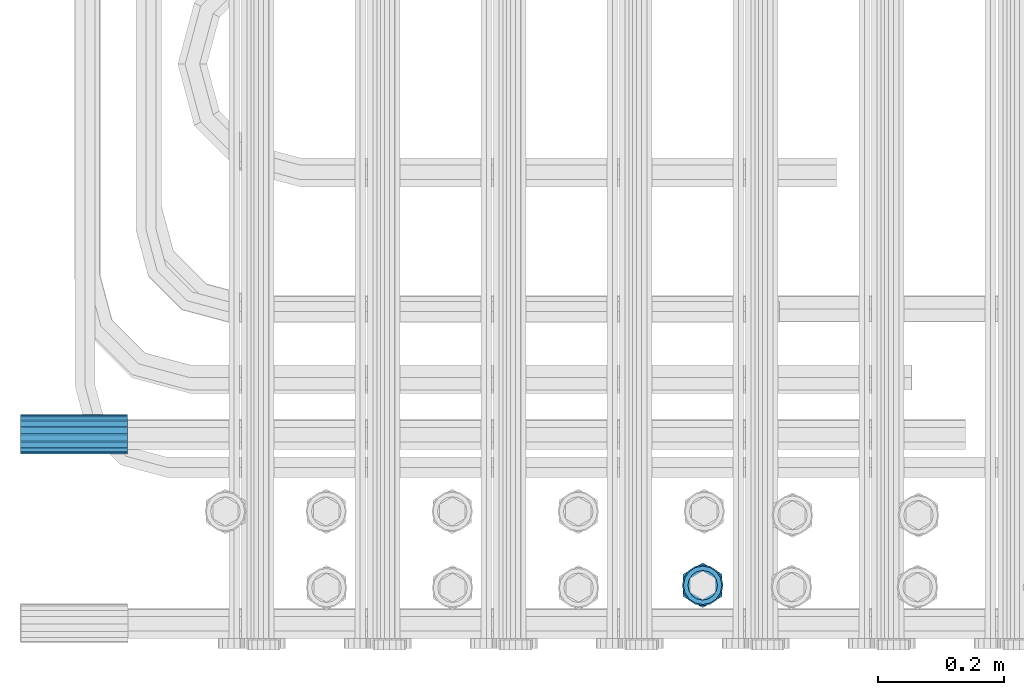
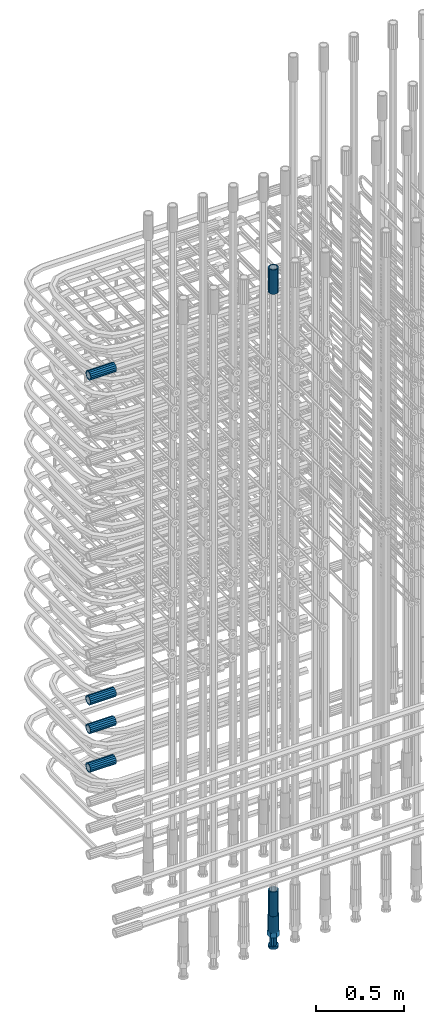
# One storey, part 31 of 177: 7 beams.
"""IFC2X3 building model written with IfcOpenShell, lengths in millimetres."""

from ifc_helpers import new_model, si_unit, frame, origin_with_axes, place, context, subcontext, project, spatial, faceted_brep, material, type_object, element, save


model = new_model("IFC2X3")

# Units and contexts
model_context_1 = context("Model", 3, precision=1e-05, world=origin_with_axes())
model_context_2 = context("Model", 3, precision=1e-05, world=origin_with_axes())
body_context = subcontext(model_context_2, "Body", "Model", "MODEL_VIEW")
ifc_project = project(units=[si_unit("LENGTHUNIT", "METRE", prefix="MILLI"), si_unit("AREAUNIT", "SQUARE_METRE"), si_unit("VOLUMEUNIT", "CUBIC_METRE"), si_unit("MASSUNIT", "GRAM", prefix="KILO"), si_unit("TIMEUNIT", "SECOND"), si_unit("PLANEANGLEUNIT", "RADIAN"), si_unit("SOLIDANGLEUNIT", "STERADIAN"), si_unit("THERMODYNAMICTEMPERATUREUNIT", "DEGREE_CELSIUS"), si_unit("LUMINOUSINTENSITYUNIT", "LUMEN")], contexts=[model_context_1])

# Site, building, storey
site_placement = place(None, origin_with_axes())
site = spatial("IfcSite", under=ifc_project, at=site_placement, CompositionType="ELEMENT")
building_placement = place(site_placement, origin_with_axes())
building = spatial("IfcBuilding", under=site, at=building_placement, Name="Undefined", CompositionType="ELEMENT")
storey_placement = place(building_placement, origin_with_axes())
storey = spatial("IfcBuildingStorey", under=building, at=storey_placement, Name="Undefined", CompositionType="ELEMENT", Elevation=0.0)

# Beams
ifc_material = material(Name="STEEL/S275")
beam_type_1 = type_object("IfcBeamType", PredefinedType="NOTDEFINED")
beam_1_placement = place(storey_placement, frame((2029920.00847313, 6205398.93588033, 22308.9883264263), z_axis=(0.0, 0.0, 1.0), x_axis=(-1.0, 0.0, 0.0)))
element("IfcBeam", 1, at=beam_1_placement, inside=storey, type_object=beam_type_1, material=ifc_material, Name="AG40N", context=body_context, shape_type="Brep", body=[
    faceted_brep([(0.0, -23.5000000001164, -9.31322574615479e-10), (0.0, -21.7111690140155, 8.99306066054851), (170.0, -21.7111690140155, 8.99306066054851), (170.0, -23.5, 0.0), (0.0, -16.6170093578839, 16.6170093575493), (170.0, -16.6170093578839, 16.6170093575493), (0.0, -8.99306066057943, 21.7111690137535), (170.0, -8.99306066057943, 21.7111690137535), (0.0, 1.16415321826935e-10, 23.5), (170.0, 0.0, 23.5), (0.0, 8.99306066057943, 21.7111690137535), (170.0, 8.99306066057943, 21.7111690137535), (0.0, 16.6170093578839, 16.6170093575493), (170.0, 16.6170093578839, 16.6170093575493), (0.0, 21.7111690140155, 8.99306066054851), (170.0, 21.7111690140155, 8.99306066054851), (0.0, 23.5000000001164, -9.31322574615479e-10), (170.0, 23.5, 0.0), (0.0, 21.7111690140155, -8.99306066054851), (170.0, 21.7111690140155, -8.99306066054851), (0.0, 16.6170093578839, -16.6170093575493), (170.0, 16.6170093578839, -16.6170093575493), (0.0, 8.99306066057943, -21.7111690137535), (170.0, 8.99306066057943, -21.7111690137535), (0.0, 1.16415321826935e-10, -23.5000000009313), (170.0, 0.0, -23.5), (0.0, -8.99306066057943, -21.7111690137535), (170.0, -8.99306066057943, -21.7111690137535), (0.0, -16.6170093578839, -16.6170093575493), (170.0, -16.6170093578839, -16.6170093575493), (0.0, -21.7111690140155, -8.99306066054851), (170.0, -21.7111690140155, -8.99306066054851), (0.0, -30.5, 0.0), (0.0, -28.1783257415937, -11.6718446873128), (170.0, -28.1783257415937, -11.6718446873128), (170.0, -30.5, 0.0), (0.0, -21.5667568261888, -21.5667568258941), (170.0, -21.5667568261888, -21.5667568258941), (0.0, -11.6718446871346, -28.1783257415518), (170.0, -11.6718446871346, -28.1783257415518), (0.0, 0.0, -30.5), (170.0, 0.0, -30.5), (0.0, 11.6718446871346, -28.1783257415518), (170.0, 11.6718446871346, -28.1783257415518), (0.0, 21.5667568261888, -21.5667568258941), (170.0, 21.5667568261888, -21.5667568258941), (0.0, 28.1783257415937, -11.6718446873128), (170.0, 28.1783257415937, -11.6718446873128), (0.0, 30.5, 0.0), (170.0, 30.5, 0.0), (0.0, 28.1783257415937, 11.6718446873128), (170.0, 28.1783257415937, 11.6718446873128), (0.0, 21.5667568261888, 21.5667568258941), (170.0, 21.5667568261888, 21.5667568258941), (0.0, 11.6718446871346, 28.1783257415518), (170.0, 11.6718446871346, 28.1783257415518), (0.0, 0.0, 30.5), (170.0, 0.0, 30.5), (0.0, -11.6718446871346, 28.1783257415518), (170.0, -11.6718446871346, 28.1783257415518), (0.0, -21.5667568261888, 21.5667568258941), (170.0, -21.5667568261888, 21.5667568258941), (0.0, -28.1783257415937, 11.6718446873128), (170.0, -28.1783257415937, 11.6718446873128)], [[[0, 1, 2, 3]], [[1, 4, 5, 2]], [[4, 6, 7, 5]], [[6, 8, 9, 7]], [[8, 10, 11, 9]], [[10, 12, 13, 11]], [[12, 14, 15, 13]], [[14, 16, 17, 15]], [[16, 18, 19, 17]], [[18, 20, 21, 19]], [[20, 22, 23, 21]], [[22, 24, 25, 23]], [[24, 26, 27, 25]], [[26, 28, 29, 27]], [[28, 30, 31, 29]], [[30, 0, 3, 31]], [[32, 33, 34, 35]], [[33, 36, 37, 34]], [[36, 38, 39, 37]], [[38, 40, 41, 39]], [[40, 42, 43, 41]], [[42, 44, 45, 43]], [[44, 46, 47, 45]], [[46, 48, 49, 47]], [[48, 50, 51, 49]], [[50, 52, 53, 51]], [[52, 54, 55, 53]], [[54, 56, 57, 55]], [[56, 58, 59, 57]], [[58, 60, 61, 59]], [[60, 62, 63, 61]], [[62, 32, 35, 63]], [[37, 39, 41, 43, 45, 47, 49, 51, 53, 55, 57, 59, 61, 63, 35, 34], [5, 7, 9, 11, 13, 15, 17, 19, 21, 23, 25, 27, 29, 31, 3, 2]], [[62, 60, 58, 56, 54, 52, 50, 48, 46, 44, 42, 40, 38, 36, 33, 32], [30, 28, 26, 24, 22, 20, 18, 16, 14, 12, 10, 8, 6, 4, 1, 0]]]),
])
beam_2_placement = place(storey_placement, frame((2030833.00241051, 6205160.29958795, 22659.9858194831), z_axis=(1.0, 0.0, 0.0), x_axis=(0.0, 0.0, 1.0)))
element("IfcBeam", 2, at=beam_2_placement, inside=storey, type_object=beam_type_1, material=ifc_material, Name="AG40N", context=body_context, shape_type="Brep", body=[
    faceted_brep([(0.0, -23.5000000001164, -9.31322574615479e-10), (0.0, -21.7111690140155, 8.99306066054851), (170.0, -21.7111690140155, 8.99306066054851), (170.0, -23.5, 0.0), (0.0, -16.6170093578839, 16.6170093575493), (170.0, -16.6170093578839, 16.6170093575493), (0.0, -8.99306066057943, 21.7111690137535), (170.0, -8.99306066057943, 21.7111690137535), (0.0, 1.16415321826935e-10, 23.5), (170.0, 0.0, 23.5), (0.0, 8.99306066057943, 21.7111690137535), (170.0, 8.99306066057943, 21.7111690137535), (0.0, 16.6170093578839, 16.6170093575493), (170.0, 16.6170093578839, 16.6170093575493), (0.0, 21.7111690140155, 8.99306066054851), (170.0, 21.7111690140155, 8.99306066054851), (0.0, 23.5000000001164, -9.31322574615479e-10), (170.0, 23.5, 0.0), (0.0, 21.7111690140155, -8.99306066054851), (170.0, 21.7111690140155, -8.99306066054851), (0.0, 16.6170093578839, -16.6170093575493), (170.0, 16.6170093578839, -16.6170093575493), (0.0, 8.99306066057943, -21.7111690137535), (170.0, 8.99306066057943, -21.7111690137535), (0.0, 1.16415321826935e-10, -23.5000000009313), (170.0, 0.0, -23.5), (0.0, -8.99306066057943, -21.7111690137535), (170.0, -8.99306066057943, -21.7111690137535), (0.0, -16.6170093578839, -16.6170093575493), (170.0, -16.6170093578839, -16.6170093575493), (0.0, -21.7111690140155, -8.99306066054851), (170.0, -21.7111690140155, -8.99306066054851), (0.0, -30.5, 0.0), (0.0, -28.1783257415937, -11.6718446873128), (170.0, -28.1783257415937, -11.6718446873128), (170.0, -30.5, 0.0), (0.0, -21.5667568261888, -21.5667568258941), (170.0, -21.5667568261888, -21.5667568258941), (0.0, -11.6718446871346, -28.1783257415518), (170.0, -11.6718446871346, -28.1783257415518), (0.0, 0.0, -30.5), (170.0, 0.0, -30.5), (0.0, 11.6718446871346, -28.1783257415518), (170.0, 11.6718446871346, -28.1783257415518), (0.0, 21.5667568261888, -21.5667568258941), (170.0, 21.5667568261888, -21.5667568258941), (0.0, 28.1783257415937, -11.6718446873128), (170.0, 28.1783257415937, -11.6718446873128), (0.0, 30.5, 0.0), (170.0, 30.5, 0.0), (0.0, 28.1783257415937, 11.6718446873128), (170.0, 28.1783257415937, 11.6718446873128), (0.0, 21.5667568261888, 21.5667568258941), (170.0, 21.5667568261888, 21.5667568258941), (0.0, 11.6718446871346, 28.1783257415518), (170.0, 11.6718446871346, 28.1783257415518), (0.0, 0.0, 30.5), (170.0, 0.0, 30.5), (0.0, -11.6718446871346, 28.1783257415518), (170.0, -11.6718446871346, 28.1783257415518), (0.0, -21.5667568261888, 21.5667568258941), (170.0, -21.5667568261888, 21.5667568258941), (0.0, -28.1783257415937, 11.6718446873128), (170.0, -28.1783257415937, 11.6718446873128)], [[[0, 1, 2, 3]], [[1, 4, 5, 2]], [[4, 6, 7, 5]], [[6, 8, 9, 7]], [[8, 10, 11, 9]], [[10, 12, 13, 11]], [[12, 14, 15, 13]], [[14, 16, 17, 15]], [[16, 18, 19, 17]], [[18, 20, 21, 19]], [[20, 22, 23, 21]], [[22, 24, 25, 23]], [[24, 26, 27, 25]], [[26, 28, 29, 27]], [[28, 30, 31, 29]], [[30, 0, 3, 31]], [[32, 33, 34, 35]], [[33, 36, 37, 34]], [[36, 38, 39, 37]], [[38, 40, 41, 39]], [[40, 42, 43, 41]], [[42, 44, 45, 43]], [[44, 46, 47, 45]], [[46, 48, 49, 47]], [[48, 50, 51, 49]], [[50, 52, 53, 51]], [[52, 54, 55, 53]], [[54, 56, 57, 55]], [[56, 58, 59, 57]], [[58, 60, 61, 59]], [[60, 62, 63, 61]], [[62, 32, 35, 63]], [[37, 39, 41, 43, 45, 47, 49, 51, 53, 55, 57, 59, 61, 63, 35, 34], [5, 7, 9, 11, 13, 15, 17, 19, 21, 23, 25, 27, 29, 31, 3, 2]], [[62, 60, 58, 56, 54, 52, 50, 48, 46, 44, 42, 40, 38, 36, 33, 32], [30, 28, 26, 24, 22, 20, 18, 16, 14, 12, 10, 8, 6, 4, 1, 0]]]),
])
beam_3_placement = place(storey_placement, frame((2030833.00241052, 6205160.29958795, 18490.9668004288), z_axis=(-1.0, 0.0, 0.0), x_axis=(0.0, 0.0, -1.0)))
element("IfcBeam", 3, at=beam_3_placement, inside=storey, type_object=beam_type_1, material=ifc_material, Name="AG40N", context=body_context, shape_type="Brep", body=[
    faceted_brep([(0.0, -23.5000000001164, -9.31322574615479e-10), (0.0, -21.7111690140155, 8.99306066054851), (170.0, -21.7111690140155, 8.99306066054851), (170.0, -23.5, 0.0), (0.0, -16.6170093578839, 16.6170093575493), (170.0, -16.6170093578839, 16.6170093575493), (0.0, -8.99306066057943, 21.7111690137535), (170.0, -8.99306066057943, 21.7111690137535), (0.0, 1.16415321826935e-10, 23.5), (170.0, 0.0, 23.5), (0.0, 8.99306066057943, 21.7111690137535), (170.0, 8.99306066057943, 21.7111690137535), (0.0, 16.6170093578839, 16.6170093575493), (170.0, 16.6170093578839, 16.6170093575493), (0.0, 21.7111690140155, 8.99306066054851), (170.0, 21.7111690140155, 8.99306066054851), (0.0, 23.5000000001164, -9.31322574615479e-10), (170.0, 23.5, 0.0), (0.0, 21.7111690140155, -8.99306066054851), (170.0, 21.7111690140155, -8.99306066054851), (0.0, 16.6170093578839, -16.6170093575493), (170.0, 16.6170093578839, -16.6170093575493), (0.0, 8.99306066057943, -21.7111690137535), (170.0, 8.99306066057943, -21.7111690137535), (0.0, 1.16415321826935e-10, -23.5000000009313), (170.0, 0.0, -23.5), (0.0, -8.99306066057943, -21.7111690137535), (170.0, -8.99306066057943, -21.7111690137535), (0.0, -16.6170093578839, -16.6170093575493), (170.0, -16.6170093578839, -16.6170093575493), (0.0, -21.7111690140155, -8.99306066054851), (170.0, -21.7111690140155, -8.99306066054851), (0.0, -30.5, 0.0), (0.0, -28.1783257415937, -11.6718446873128), (170.0, -28.1783257415937, -11.6718446873128), (170.0, -30.5, 0.0), (0.0, -21.5667568261888, -21.5667568258941), (170.0, -21.5667568261888, -21.5667568258941), (0.0, -11.6718446871346, -28.1783257415518), (170.0, -11.6718446871346, -28.1783257415518), (0.0, 0.0, -30.5), (170.0, 0.0, -30.5), (0.0, 11.6718446871346, -28.1783257415518), (170.0, 11.6718446871346, -28.1783257415518), (0.0, 21.5667568261888, -21.5667568258941), (170.0, 21.5667568261888, -21.5667568258941), (0.0, 28.1783257415937, -11.6718446873128), (170.0, 28.1783257415937, -11.6718446873128), (0.0, 30.5, 0.0), (170.0, 30.5, 0.0), (0.0, 28.1783257415937, 11.6718446873128), (170.0, 28.1783257415937, 11.6718446873128), (0.0, 21.5667568261888, 21.5667568258941), (170.0, 21.5667568261888, 21.5667568258941), (0.0, 11.6718446871346, 28.1783257415518), (170.0, 11.6718446871346, 28.1783257415518), (0.0, 0.0, 30.5), (170.0, 0.0, 30.5), (0.0, -11.6718446871346, 28.1783257415518), (170.0, -11.6718446871346, 28.1783257415518), (0.0, -21.5667568261888, 21.5667568258941), (170.0, -21.5667568261888, 21.5667568258941), (0.0, -28.1783257415937, 11.6718446873128), (170.0, -28.1783257415937, 11.6718446873128)], [[[0, 1, 2, 3]], [[1, 4, 5, 2]], [[4, 6, 7, 5]], [[6, 8, 9, 7]], [[8, 10, 11, 9]], [[10, 12, 13, 11]], [[12, 14, 15, 13]], [[14, 16, 17, 15]], [[16, 18, 19, 17]], [[18, 20, 21, 19]], [[20, 22, 23, 21]], [[22, 24, 25, 23]], [[24, 26, 27, 25]], [[26, 28, 29, 27]], [[28, 30, 31, 29]], [[30, 0, 3, 31]], [[32, 33, 34, 35]], [[33, 36, 37, 34]], [[36, 38, 39, 37]], [[38, 40, 41, 39]], [[40, 42, 43, 41]], [[42, 44, 45, 43]], [[44, 46, 47, 45]], [[46, 48, 49, 47]], [[48, 50, 51, 49]], [[50, 52, 53, 51]], [[52, 54, 55, 53]], [[54, 56, 57, 55]], [[56, 58, 59, 57]], [[58, 60, 61, 59]], [[60, 62, 63, 61]], [[62, 32, 35, 63]], [[37, 39, 41, 43, 45, 47, 49, 51, 53, 55, 57, 59, 61, 63, 35, 34], [5, 7, 9, 11, 13, 15, 17, 19, 21, 23, 25, 27, 29, 31, 3, 2]], [[62, 60, 58, 56, 54, 52, 50, 48, 46, 44, 42, 40, 38, 36, 33, 32], [30, 28, 26, 24, 22, 20, 18, 16, 14, 12, 10, 8, 6, 4, 1, 0]]]),
])
beam_4_placement = place(storey_placement, frame((2029920.00847313, 6205400.93588033, 19571.8883264263), z_axis=(0.0, 0.0, -1.0), x_axis=(-1.0, 0.0, 0.0)))
element("IfcBeam", 4, at=beam_4_placement, inside=storey, type_object=beam_type_1, material=ifc_material, Name="AG40N", context=body_context, shape_type="Brep", body=[
    faceted_brep([(0.0, -23.5000000001164, -9.31322574615479e-10), (0.0, -21.7111690140155, 8.99306066054851), (170.0, -21.7111690140155, 8.99306066054851), (170.0, -23.5, 0.0), (0.0, -16.6170093578839, 16.6170093575493), (170.0, -16.6170093578839, 16.6170093575493), (0.0, -8.99306066057943, 21.7111690137535), (170.0, -8.99306066057943, 21.7111690137535), (0.0, 1.16415321826935e-10, 23.5), (170.0, 0.0, 23.5), (0.0, 8.99306066057943, 21.7111690137535), (170.0, 8.99306066057943, 21.7111690137535), (0.0, 16.6170093578839, 16.6170093575493), (170.0, 16.6170093578839, 16.6170093575493), (0.0, 21.7111690140155, 8.99306066054851), (170.0, 21.7111690140155, 8.99306066054851), (0.0, 23.5000000001164, -9.31322574615479e-10), (170.0, 23.5, 0.0), (0.0, 21.7111690140155, -8.99306066054851), (170.0, 21.7111690140155, -8.99306066054851), (0.0, 16.6170093578839, -16.6170093575493), (170.0, 16.6170093578839, -16.6170093575493), (0.0, 8.99306066057943, -21.7111690137535), (170.0, 8.99306066057943, -21.7111690137535), (0.0, 1.16415321826935e-10, -23.5000000009313), (170.0, 0.0, -23.5), (0.0, -8.99306066057943, -21.7111690137535), (170.0, -8.99306066057943, -21.7111690137535), (0.0, -16.6170093578839, -16.6170093575493), (170.0, -16.6170093578839, -16.6170093575493), (0.0, -21.7111690140155, -8.99306066054851), (170.0, -21.7111690140155, -8.99306066054851), (0.0, -30.5, 0.0), (0.0, -28.1783257415937, -11.6718446873128), (170.0, -28.1783257415937, -11.6718446873128), (170.0, -30.5, 0.0), (0.0, -21.5667568261888, -21.5667568258941), (170.0, -21.5667568261888, -21.5667568258941), (0.0, -11.6718446871346, -28.1783257415518), (170.0, -11.6718446871346, -28.1783257415518), (0.0, 0.0, -30.5), (170.0, 0.0, -30.5), (0.0, 11.6718446871346, -28.1783257415518), (170.0, 11.6718446871346, -28.1783257415518), (0.0, 21.5667568261888, -21.5667568258941), (170.0, 21.5667568261888, -21.5667568258941), (0.0, 28.1783257415937, -11.6718446873128), (170.0, 28.1783257415937, -11.6718446873128), (0.0, 30.5, 0.0), (170.0, 30.5, 0.0), (0.0, 28.1783257415937, 11.6718446873128), (170.0, 28.1783257415937, 11.6718446873128), (0.0, 21.5667568261888, 21.5667568258941), (170.0, 21.5667568261888, 21.5667568258941), (0.0, 11.6718446871346, 28.1783257415518), (170.0, 11.6718446871346, 28.1783257415518), (0.0, 0.0, 30.5), (170.0, 0.0, 30.5), (0.0, -11.6718446871346, 28.1783257415518), (170.0, -11.6718446871346, 28.1783257415518), (0.0, -21.5667568261888, 21.5667568258941), (170.0, -21.5667568261888, 21.5667568258941), (0.0, -28.1783257415937, 11.6718446873128), (170.0, -28.1783257415937, 11.6718446873128)], [[[0, 1, 2, 3]], [[1, 4, 5, 2]], [[4, 6, 7, 5]], [[6, 8, 9, 7]], [[8, 10, 11, 9]], [[10, 12, 13, 11]], [[12, 14, 15, 13]], [[14, 16, 17, 15]], [[16, 18, 19, 17]], [[18, 20, 21, 19]], [[20, 22, 23, 21]], [[22, 24, 25, 23]], [[24, 26, 27, 25]], [[26, 28, 29, 27]], [[28, 30, 31, 29]], [[30, 0, 3, 31]], [[32, 33, 34, 35]], [[33, 36, 37, 34]], [[36, 38, 39, 37]], [[38, 40, 41, 39]], [[40, 42, 43, 41]], [[42, 44, 45, 43]], [[44, 46, 47, 45]], [[46, 48, 49, 47]], [[48, 50, 51, 49]], [[50, 52, 53, 51]], [[52, 54, 55, 53]], [[54, 56, 57, 55]], [[56, 58, 59, 57]], [[58, 60, 61, 59]], [[60, 62, 63, 61]], [[62, 32, 35, 63]], [[37, 39, 41, 43, 45, 47, 49, 51, 53, 55, 57, 59, 61, 63, 35, 34], [5, 7, 9, 11, 13, 15, 17, 19, 21, 23, 25, 27, 29, 31, 3, 2]], [[62, 60, 58, 56, 54, 52, 50, 48, 46, 44, 42, 40, 38, 36, 33, 32], [30, 28, 26, 24, 22, 20, 18, 16, 14, 12, 10, 8, 6, 4, 1, 0]]]),
])
beam_5_placement = place(storey_placement, frame((2029920.00847313, 6205400.93588033, 19841.8883264263), z_axis=(0.0, 0.0, -1.0), x_axis=(-1.0, 0.0, 0.0)))
element("IfcBeam", 5, at=beam_5_placement, inside=storey, type_object=beam_type_1, material=ifc_material, Name="AG40N", context=body_context, shape_type="Brep", body=[
    faceted_brep([(0.0, -23.5000000001164, -9.31322574615479e-10), (0.0, -21.7111690140155, 8.99306066054851), (170.0, -21.7111690140155, 8.99306066054851), (170.0, -23.5, 0.0), (0.0, -16.6170093578839, 16.6170093575493), (170.0, -16.6170093578839, 16.6170093575493), (0.0, -8.99306066057943, 21.7111690137535), (170.0, -8.99306066057943, 21.7111690137535), (0.0, 1.16415321826935e-10, 23.5), (170.0, 0.0, 23.5), (0.0, 8.99306066057943, 21.7111690137535), (170.0, 8.99306066057943, 21.7111690137535), (0.0, 16.6170093578839, 16.6170093575493), (170.0, 16.6170093578839, 16.6170093575493), (0.0, 21.7111690140155, 8.99306066054851), (170.0, 21.7111690140155, 8.99306066054851), (0.0, 23.5000000001164, -9.31322574615479e-10), (170.0, 23.5, 0.0), (0.0, 21.7111690140155, -8.99306066054851), (170.0, 21.7111690140155, -8.99306066054851), (0.0, 16.6170093578839, -16.6170093575493), (170.0, 16.6170093578839, -16.6170093575493), (0.0, 8.99306066057943, -21.7111690137535), (170.0, 8.99306066057943, -21.7111690137535), (0.0, 1.16415321826935e-10, -23.5000000009313), (170.0, 0.0, -23.5), (0.0, -8.99306066057943, -21.7111690137535), (170.0, -8.99306066057943, -21.7111690137535), (0.0, -16.6170093578839, -16.6170093575493), (170.0, -16.6170093578839, -16.6170093575493), (0.0, -21.7111690140155, -8.99306066054851), (170.0, -21.7111690140155, -8.99306066054851), (0.0, -30.5, 0.0), (0.0, -28.1783257415937, -11.6718446873128), (170.0, -28.1783257415937, -11.6718446873128), (170.0, -30.5, 0.0), (0.0, -21.5667568261888, -21.5667568258941), (170.0, -21.5667568261888, -21.5667568258941), (0.0, -11.6718446871346, -28.1783257415518), (170.0, -11.6718446871346, -28.1783257415518), (0.0, 0.0, -30.5), (170.0, 0.0, -30.5), (0.0, 11.6718446871346, -28.1783257415518), (170.0, 11.6718446871346, -28.1783257415518), (0.0, 21.5667568261888, -21.5667568258941), (170.0, 21.5667568261888, -21.5667568258941), (0.0, 28.1783257415937, -11.6718446873128), (170.0, 28.1783257415937, -11.6718446873128), (0.0, 30.5, 0.0), (170.0, 30.5, 0.0), (0.0, 28.1783257415937, 11.6718446873128), (170.0, 28.1783257415937, 11.6718446873128), (0.0, 21.5667568261888, 21.5667568258941), (170.0, 21.5667568261888, 21.5667568258941), (0.0, 11.6718446871346, 28.1783257415518), (170.0, 11.6718446871346, 28.1783257415518), (0.0, 0.0, 30.5), (170.0, 0.0, 30.5), (0.0, -11.6718446871346, 28.1783257415518), (170.0, -11.6718446871346, 28.1783257415518), (0.0, -21.5667568261888, 21.5667568258941), (170.0, -21.5667568261888, 21.5667568258941), (0.0, -28.1783257415937, 11.6718446873128), (170.0, -28.1783257415937, 11.6718446873128)], [[[0, 1, 2, 3]], [[1, 4, 5, 2]], [[4, 6, 7, 5]], [[6, 8, 9, 7]], [[8, 10, 11, 9]], [[10, 12, 13, 11]], [[12, 14, 15, 13]], [[14, 16, 17, 15]], [[16, 18, 19, 17]], [[18, 20, 21, 19]], [[20, 22, 23, 21]], [[22, 24, 25, 23]], [[24, 26, 27, 25]], [[26, 28, 29, 27]], [[28, 30, 31, 29]], [[30, 0, 3, 31]], [[32, 33, 34, 35]], [[33, 36, 37, 34]], [[36, 38, 39, 37]], [[38, 40, 41, 39]], [[40, 42, 43, 41]], [[42, 44, 45, 43]], [[44, 46, 47, 45]], [[46, 48, 49, 47]], [[48, 50, 51, 49]], [[50, 52, 53, 51]], [[52, 54, 55, 53]], [[54, 56, 57, 55]], [[56, 58, 59, 57]], [[58, 60, 61, 59]], [[60, 62, 63, 61]], [[62, 32, 35, 63]], [[37, 39, 41, 43, 45, 47, 49, 51, 53, 55, 57, 59, 61, 63, 35, 34], [5, 7, 9, 11, 13, 15, 17, 19, 21, 23, 25, 27, 29, 31, 3, 2]], [[62, 60, 58, 56, 54, 52, 50, 48, 46, 44, 42, 40, 38, 36, 33, 32], [30, 28, 26, 24, 22, 20, 18, 16, 14, 12, 10, 8, 6, 4, 1, 0]]]),
])
beam_6_placement = place(storey_placement, frame((2029920.00847313, 6205400.93588033, 20041.8883264263), z_axis=(0.0, 0.0, -1.0), x_axis=(-1.0, 0.0, 0.0)))
element("IfcBeam", 6, at=beam_6_placement, inside=storey, type_object=beam_type_1, material=ifc_material, Name="AG40N", context=body_context, shape_type="Brep", body=[
    faceted_brep([(0.0, -23.5000000001164, -9.31322574615479e-10), (0.0, -21.7111690140155, 8.99306066054851), (170.0, -21.7111690140155, 8.99306066054851), (170.0, -23.5, 0.0), (0.0, -16.6170093578839, 16.6170093575493), (170.0, -16.6170093578839, 16.6170093575493), (0.0, -8.99306066057943, 21.7111690137535), (170.0, -8.99306066057943, 21.7111690137535), (0.0, 1.16415321826935e-10, 23.5), (170.0, 0.0, 23.5), (0.0, 8.99306066057943, 21.7111690137535), (170.0, 8.99306066057943, 21.7111690137535), (0.0, 16.6170093578839, 16.6170093575493), (170.0, 16.6170093578839, 16.6170093575493), (0.0, 21.7111690140155, 8.99306066054851), (170.0, 21.7111690140155, 8.99306066054851), (0.0, 23.5000000001164, -9.31322574615479e-10), (170.0, 23.5, 0.0), (0.0, 21.7111690140155, -8.99306066054851), (170.0, 21.7111690140155, -8.99306066054851), (0.0, 16.6170093578839, -16.6170093575493), (170.0, 16.6170093578839, -16.6170093575493), (0.0, 8.99306066057943, -21.7111690137535), (170.0, 8.99306066057943, -21.7111690137535), (0.0, 1.16415321826935e-10, -23.5000000009313), (170.0, 0.0, -23.5), (0.0, -8.99306066057943, -21.7111690137535), (170.0, -8.99306066057943, -21.7111690137535), (0.0, -16.6170093578839, -16.6170093575493), (170.0, -16.6170093578839, -16.6170093575493), (0.0, -21.7111690140155, -8.99306066054851), (170.0, -21.7111690140155, -8.99306066054851), (0.0, -30.5, 0.0), (0.0, -28.1783257415937, -11.6718446873128), (170.0, -28.1783257415937, -11.6718446873128), (170.0, -30.5, 0.0), (0.0, -21.5667568261888, -21.5667568258941), (170.0, -21.5667568261888, -21.5667568258941), (0.0, -11.6718446871346, -28.1783257415518), (170.0, -11.6718446871346, -28.1783257415518), (0.0, 0.0, -30.5), (170.0, 0.0, -30.5), (0.0, 11.6718446871346, -28.1783257415518), (170.0, 11.6718446871346, -28.1783257415518), (0.0, 21.5667568261888, -21.5667568258941), (170.0, 21.5667568261888, -21.5667568258941), (0.0, 28.1783257415937, -11.6718446873128), (170.0, 28.1783257415937, -11.6718446873128), (0.0, 30.5, 0.0), (170.0, 30.5, 0.0), (0.0, 28.1783257415937, 11.6718446873128), (170.0, 28.1783257415937, 11.6718446873128), (0.0, 21.5667568261888, 21.5667568258941), (170.0, 21.5667568261888, 21.5667568258941), (0.0, 11.6718446871346, 28.1783257415518), (170.0, 11.6718446871346, 28.1783257415518), (0.0, 0.0, 30.5), (170.0, 0.0, 30.5), (0.0, -11.6718446871346, 28.1783257415518), (170.0, -11.6718446871346, 28.1783257415518), (0.0, -21.5667568261888, 21.5667568258941), (170.0, -21.5667568261888, 21.5667568258941), (0.0, -28.1783257415937, 11.6718446873128), (170.0, -28.1783257415937, 11.6718446873128)], [[[0, 1, 2, 3]], [[1, 4, 5, 2]], [[4, 6, 7, 5]], [[6, 8, 9, 7]], [[8, 10, 11, 9]], [[10, 12, 13, 11]], [[12, 14, 15, 13]], [[14, 16, 17, 15]], [[16, 18, 19, 17]], [[18, 20, 21, 19]], [[20, 22, 23, 21]], [[22, 24, 25, 23]], [[24, 26, 27, 25]], [[26, 28, 29, 27]], [[28, 30, 31, 29]], [[30, 0, 3, 31]], [[32, 33, 34, 35]], [[33, 36, 37, 34]], [[36, 38, 39, 37]], [[38, 40, 41, 39]], [[40, 42, 43, 41]], [[42, 44, 45, 43]], [[44, 46, 47, 45]], [[46, 48, 49, 47]], [[48, 50, 51, 49]], [[50, 52, 53, 51]], [[52, 54, 55, 53]], [[54, 56, 57, 55]], [[56, 58, 59, 57]], [[58, 60, 61, 59]], [[60, 62, 63, 61]], [[62, 32, 35, 63]], [[37, 39, 41, 43, 45, 47, 49, 51, 53, 55, 57, 59, 61, 63, 35, 34], [5, 7, 9, 11, 13, 15, 17, 19, 21, 23, 25, 27, 29, 31, 3, 2]], [[62, 60, 58, 56, 54, 52, 50, 48, 46, 44, 42, 40, 38, 36, 33, 32], [30, 28, 26, 24, 22, 20, 18, 16, 14, 12, 10, 8, 6, 4, 1, 0]]]),
])
beam_type_2 = type_object("IfcBeamType", Name="ROD65", PredefinedType="NOTDEFINED")
beam_7_placement = place(storey_placement, frame((2030833.00241052, 6205160.29958795, 18320.9668004288), z_axis=(-1.0, 0.0, 0.0), x_axis=(0.0, 0.0, -1.0)))
element("IfcBeam", 7, at=beam_7_placement, inside=storey, type_object=beam_type_2, material=ifc_material, Name="AGB40", ObjectType="ROD65", context=body_context, shape_type="Brep", body=[
    faceted_brep([(117.0, 8.17543110251427, 30.873805644922), (117.0, 17.8250000001863, 30.873805644922), (117.0, 22.0056958701462, 23.6326279877685), (117.0, 12.4372115517035, 30.0260848065373), (117.0, -17.8250000001863, 30.873805644922), (150.200000000186, -17.8250000001863, 30.873805644922), (150.200000000186, 17.8250000001863, 30.873805644922), (117.0, -8.17543110251427, 30.873805644922), (117.0, -12.4372115517035, 30.0260848065373), (117.0, -22.0056958701462, 23.6326279877685), (117.0, -35.6500000003725, 0.0), (150.200000000186, -35.6500000003725, 0.0), (117.0, -30.8443150008097, 8.32369058486074), (117.0, -32.5, 0.0), (117.0, -30.8443150008097, -8.32369058462791), (117.0, -17.8250000001863, -30.873805644922), (150.200000000186, -17.8250000001863, -30.873805644922), (117.0, -22.0056958701462, -23.6326279877685), (117.0, -12.4372115517035, -30.0260848065373), (117.0, -8.17543110251427, -30.873805644922), (117.0, 17.8250000001863, -30.873805644922), (150.200000000186, 17.8250000001863, -30.873805644922), (117.0, 8.17543110251427, -30.873805644922), (117.0, 22.0056958701462, -23.6326279877685), (117.0, 12.4372115517035, -30.0260848065373), (117.0, 35.6500000003725, 0.0), (150.200000000186, 35.6500000003725, 0.0), (117.0, 30.8443150008097, -8.32369058486074), (117.0, 30.8443150008097, 8.32369058462791), (117.0, 32.5, 0.0), (0.0, -22.9809703892097, 22.9809703885621), (0.0, -30.0260848058388, 12.4372115518636), (117.0, -30.0260848067701, 12.4372115519363), (117.0, -22.9809703882784, 22.9809703885112), (-2.3283064365387e-10, 22.9809703892097, -22.9809703885639), (-4.65661287307739e-10, 30.0260848077014, -12.4372115518672), (117.0, 30.0260848067701, -12.4372115519363), (117.0, 22.9809703882784, -22.9809703885112), (-2.3283064365387e-10, -30.0260848067701, -12.4372115518672), (-2.3283064365387e-10, -22.9809703892097, -22.9809703885621), (117.0, -22.9809703882784, -22.9809703885112), (117.0, -30.0260848067701, -12.4372115519363), (-2.3283064365387e-10, -12.4372115507722, 30.0260848066137), (-2.3283064365387e-10, 9.31322574615479e-10, 32.4999999999982), (-2.3283064365387e-10, 12.4372115526348, 30.0260848066137), (0.0, 22.9809703892097, 22.9809703885621), (-2.3283064365387e-10, 30.0260848077014, 12.4372115518636), (-2.3283064365387e-10, 32.5, 0.0), (-2.3283064365387e-10, 12.4372115526348, -30.0260848066173), (-2.3283064365387e-10, 9.31322574615479e-10, -32.5), (-2.3283064365387e-10, -12.4372115517035, -30.0260848066173), (-4.65661287307739e-10, -32.4999999990687, -1.81898940354586e-12), (117.0, 22.9809703882784, 22.9809703885112), (117.0, 30.0260848067701, 12.4372115519363), (117.0, 0.0, -32.5), (117.0, 0.0, 32.5), (150.200000000186, 10.5, -18.1865334794857), (150.200000000186, 0.0, -21.0), (150.200000000186, -10.5, -18.1865334794857), (150.200000000186, -18.18653347902, -10.5), (150.200000000186, -21.0, 0.0), (150.200000000186, -18.18653347902, 10.5), (150.200000000186, -10.5, 18.1865334794857), (150.200000000186, 0.0, 21.0), (150.200000000186, 10.5, 18.1865334794857), (150.200000000186, 18.18653347902, 10.5), (150.200000000186, 21.0, 0.0), (150.200000000186, 18.18653347902, -10.5), (210.980000000447, -10.5, -18.1865334794857), (210.980000000447, 0.0, -21.0), (210.980000000447, -18.18653347902, -10.5), (210.980000000447, -21.0, 0.0), (210.980000000447, -18.18653347902, 10.5), (210.980000000447, -10.5, 18.1865334794857), (210.980000000447, 0.0, 21.0), (210.980000000447, 10.5, 18.1865334794857), (210.980000000447, 18.18653347902, 10.5), (210.980000000447, 21.0, 0.0), (210.980000000447, 18.18653347902, -10.5), (210.980000000447, 10.5, -18.1865334794857), (211.001368442696, -27.7269937992096, -11.491116326768), (211.003082550167, -21.2238094303757, -21.223815418547), (231.002518367059, -21.2131944671273, -21.2132004550658), (231.000804259587, -27.7163788359612, -11.4805013632867), (211.001368440451, -11.4911085031927, -27.7269970395137), (231.000804257343, -11.4804935399443, -27.7163820760325), (210.996487071217, -0.0106065049767494, -30.0106107392348), (230.995922888109, 8.45827162265778e-06, -29.9999957757536), (210.989181586672, 11.46989420522, -27.7269970329944), (230.988617403564, 11.4805091684684, -27.7163820695132), (210.980564180623, 21.2025914648548, -21.2238154064398), (230.979999997515, 21.2132064281031, -21.2132004429586), (210.971946775022, 27.7057703435421, -11.4911163107026), (230.971382591913, 27.7163853067905, -11.4805013472214), (210.96464129175, 29.9893808094785, -0.0106149562634528), (230.964077108642, 29.9999957727268, 7.21774995326996e-09), (210.959759924415, 27.7057638689876, 11.4698863970116), (230.959195741307, 27.7163788322359, 11.4805013604928), (210.958045816944, 21.2025795001537, 21.2025854887906), (230.957481633835, 21.213194463402, 21.2132004522718), (210.95975992666, 11.4698785729706, 27.7057671097573), (230.959195743551, 11.480493536219, 27.7163820732385), (210.964641295894, -0.010623425245285, 29.9893808094785), (230.964077112785, -8.46199691295624e-06, 29.9999957729597), (210.971946780439, -11.4911241354421, 27.705767103238), (230.97138259733, -11.4805091721937, 27.7163820667192), (210.980564186488, -21.2238213950768, 21.2025854766835), (230.980000003379, -21.2132064318284, 21.2132004401647), (210.989181592089, -27.7270002737641, 11.4698863809463), (230.988617408981, -27.7163853105158, 11.4805013444275), (210.996487075361, -30.0106107397005, -0.0106149734929204), (230.995922892253, -29.9999957764521, -1.00117176771164e-08)], [[[0, 1, 2, 3]], [[4, 5, 6, 1, 0, 7]], [[4, 7, 8, 9]], [[10, 11, 5, 4, 9, 12]], [[10, 12, 13, 14]], [[15, 16, 11, 10, 14, 17]], [[15, 17, 18, 19]], [[20, 21, 16, 15, 19, 22]], [[23, 20, 22, 24]], [[25, 26, 21, 20, 23, 27]], [[28, 25, 27, 29]], [[30, 31, 32, 33]], [[34, 35, 36, 37]], [[38, 39, 40, 41]], [[31, 30, 42, 43, 44, 45, 46, 47, 35, 34, 48, 49, 50, 39, 38, 51]], [[46, 45, 52, 53]], [[29, 47, 46, 53, 28]], [[27, 36, 35, 47, 29]], [[23, 37, 36, 27]], [[24, 48, 34, 37, 23]], [[22, 54, 49, 48, 24]], [[19, 54, 22]], [[18, 50, 49, 54, 19]], [[17, 40, 39, 50, 18]], [[14, 41, 40, 17]], [[13, 51, 38, 41, 14]], [[12, 32, 31, 51, 13]], [[9, 33, 32, 12]], [[8, 42, 30, 33, 9]], [[7, 55, 43, 42, 8]], [[0, 55, 7]], [[3, 44, 43, 55, 0]], [[2, 52, 45, 44, 3]], [[28, 53, 52, 2]], [[1, 6, 26, 25, 28, 2]], [[5, 11, 16, 21, 26, 6], [56, 57, 58, 59, 60, 61, 62, 63, 64, 65, 66, 67]], [[68, 58, 57, 69]], [[70, 59, 58, 68]], [[71, 60, 59, 70]], [[72, 61, 60, 71]], [[73, 62, 61, 72]], [[74, 63, 62, 73]], [[75, 64, 63, 74]], [[76, 65, 64, 75]], [[77, 66, 65, 76]], [[78, 67, 66, 77]], [[79, 56, 67, 78]], [[69, 57, 56, 79]], [[80, 81, 82, 83]], [[81, 84, 85, 82]], [[84, 86, 87, 85]], [[86, 88, 89, 87]], [[88, 90, 91, 89]], [[90, 92, 93, 91]], [[92, 94, 95, 93]], [[94, 96, 97, 95]], [[96, 98, 99, 97]], [[98, 100, 101, 99]], [[100, 102, 103, 101]], [[102, 104, 105, 103]], [[104, 106, 107, 105]], [[106, 108, 109, 107]], [[108, 110, 111, 109]], [[82, 85, 87, 89, 91, 93, 95, 97, 99, 101, 103, 105, 107, 109, 111, 83]], [[110, 80, 83, 111]], [[108, 106, 104, 102, 100, 98, 96, 94, 92, 90, 88, 86, 84, 81, 80, 110], [78, 77, 76, 75, 74, 73, 72, 71, 70, 68, 69, 79]]]),
])

save(model, "model.ifc")
